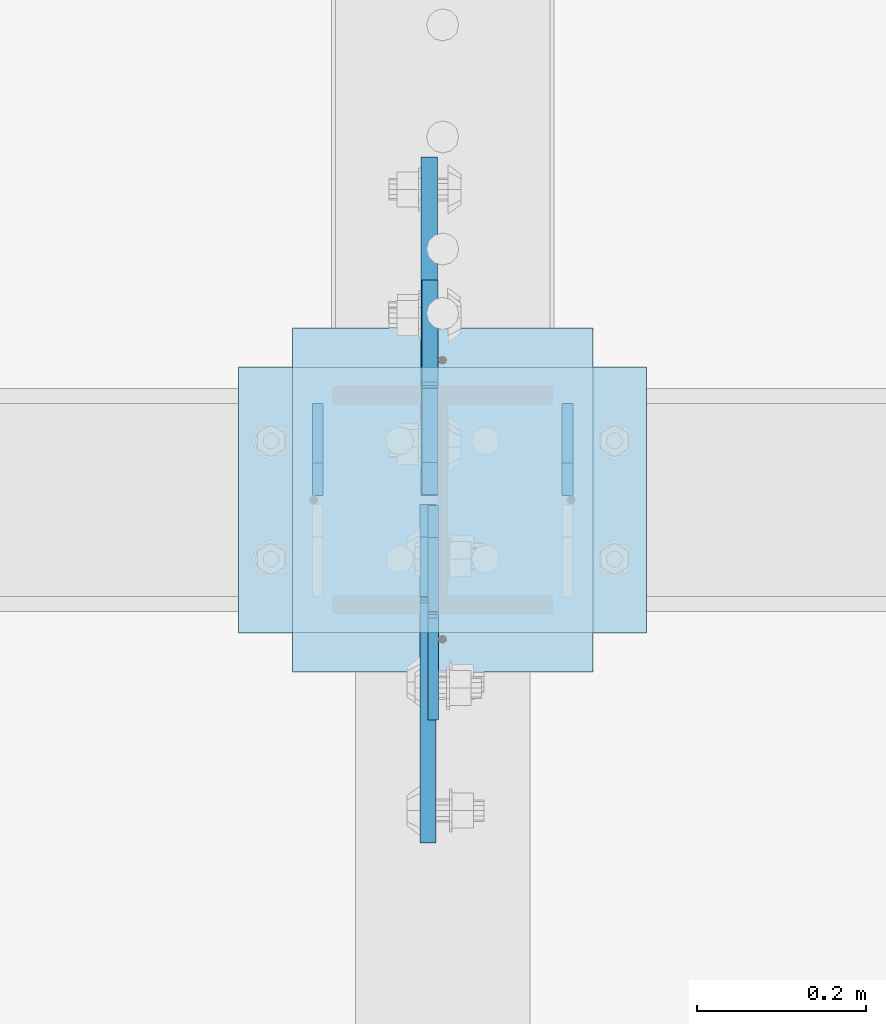
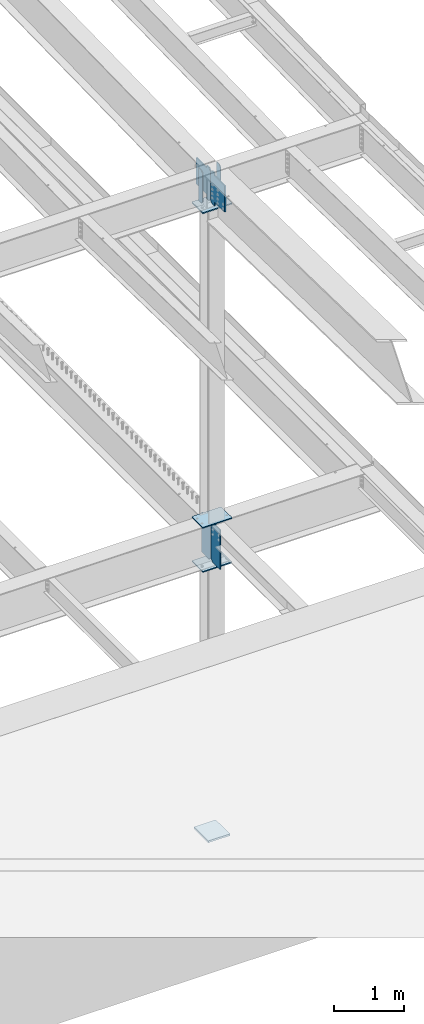
# One storey, part 1583 of 1763: 10 plates, 4 elements without a shape of their own.
"""IFC2X3 building model written with IfcOpenShell, lengths in millimetres."""

from ifc_helpers import new_model, si_unit, frame, origin_with_axes, place, context, subcontext, project, spatial, faceted_brep, material, type_object, element, aggregate, save


model = new_model("IFC2X3")

# Units and contexts
model_context = context("Model", 3, precision=1e-05, world=origin_with_axes())
body_context = subcontext(model_context, "Body", "Model", "MODEL_VIEW")
ifc_project = project(units=[si_unit("LENGTHUNIT", "METRE", prefix="MILLI"), si_unit("AREAUNIT", "SQUARE_METRE"), si_unit("VOLUMEUNIT", "CUBIC_METRE"), si_unit("MASSUNIT", "GRAM", prefix="KILO"), si_unit("TIMEUNIT", "SECOND"), si_unit("PLANEANGLEUNIT", "RADIAN"), si_unit("SOLIDANGLEUNIT", "STERADIAN"), si_unit("THERMODYNAMICTEMPERATUREUNIT", "DEGREE_CELSIUS"), si_unit("LUMINOUSINTENSITYUNIT", "LUMEN")], contexts=[model_context])

# Site, building, storey
site_placement = place(None, origin_with_axes())
site = spatial("IfcSite", under=ifc_project, at=site_placement, CompositionType="ELEMENT")
building_placement = place(site_placement, origin_with_axes())
building = spatial("IfcBuilding", under=site, at=building_placement, Name="Undefined", CompositionType="ELEMENT")
storey_placement = place(building_placement, origin_with_axes())
storey = spatial("IfcBuildingStorey", under=building, at=storey_placement, Name="Undefined", CompositionType="ELEMENT", Elevation=0.0)

# Assembly, plates
assembly_1_placement = place(storey_placement, origin_with_axes())
assembly_1 = element("IfcElementAssembly", 1, at=assembly_1_placement, inside=storey, Name="BEAM", AssemblyPlace="NOTDEFINED", PredefinedType="RIGID_FRAME")
ifc_material_1 = material(Name="STEEL/A572-50")
plate_type_1 = type_object("IfcPlateType", PredefinedType="NOTDEFINED")
plate_1_placement = place(assembly_1_placement, frame((-24175.4747736984, 30137.1000001452, 11272.8374999952), z_axis=(0.0, 0.0, -1.0), x_axis=(0.0, -1.0, 0.0)))
plate_1 = element("IfcPlate", 2, at=plate_1_placement, type_object=plate_type_1, material=ifc_material_1, Name="PLATE", context=body_context, shape_type="Brep", body=[
    faceted_brep([(0.0, -6.34999999999491, 1.45519152283669e-11), (0.0, -6.34999999999854, 571.5), (0.0, 6.34999999999854, 571.5), (0.0, 6.34999999999491, -2.91038304567337e-11), (70.6437530517578, -6.34999999999854, 571.5), (70.6437530517578, 6.34999999999854, 571.5), (108.743751525879, -6.34999999999854, 533.400001525879), (108.743751525879, 6.34999999999854, 533.400001525879), (108.743751525879, -6.34999999999854, 38.0999984741211), (108.743751525879, 6.34999999999854, 38.0999984741211), (70.6437530517578, -6.34999999999854, 0.0), (70.6437530517578, 6.34999999999854, 0.0)], [[[0, 1, 2, 3]], [[1, 4, 5, 2]], [[4, 6, 7, 5]], [[6, 8, 9, 7]], [[8, 10, 11, 9]], [[10, 0, 3, 11]], [[5, 7, 9, 11, 3, 2]], [[10, 8, 6, 4, 1, 0]]]),
])
plate_2_placement = place(assembly_1_placement, frame((-23880.1997736984, 30137.1000001452, 11272.8374999952), z_axis=(0.0, 0.0, -1.0), x_axis=(0.0, -1.0, 0.0)))
plate_2 = element("IfcPlate", 3, at=plate_2_placement, type_object=plate_type_1, material=ifc_material_1, Name="PLATE", context=body_context, shape_type="Brep", body=[
    faceted_brep([(0.0, -6.34999999999491, 1.45519152283669e-11), (0.0, -6.34999999999854, 571.5), (0.0, 6.34999999999854, 571.5), (0.0, 6.34999999999491, -2.91038304567337e-11), (70.6437530517578, -6.34999999999854, 571.5), (70.6437530517578, 6.34999999999854, 571.5), (108.743751525879, -6.34999999999854, 533.400001525879), (108.743751525879, 6.34999999999854, 533.400001525879), (108.743751525879, -6.34999999999854, 38.0999984741211), (108.743751525879, 6.34999999999854, 38.0999984741211), (70.6437530517578, -6.34999999999854, 0.0), (70.6437530517578, 6.34999999999854, 0.0)], [[[0, 1, 2, 3]], [[1, 4, 5, 2]], [[4, 6, 7, 5]], [[6, 8, 9, 7]], [[8, 10, 11, 9]], [[10, 0, 3, 11]], [[5, 7, 9, 11, 3, 2]], [[10, 8, 6, 4, 1, 0]]]),
])

# Assembly, plate
assembly_2_placement = place(storey_placement, origin_with_axes())
assembly_2 = element("IfcElementAssembly", 4, at=assembly_2_placement, inside=storey, Name="COLUMN", AssemblyPlace="NOTDEFINED", PredefinedType="RIGID_FRAME")
plate_type_2 = type_object("IfcPlateType", PredefinedType="NOTDEFINED")
plate_3_placement = place(assembly_2_placement, frame((-24269.1372736984, 30179.9625, 5203.825), z_axis=(1.0, 0.0, 0.0), x_axis=(0.0, -1.0, 0.0)))
plate_3 = element("IfcPlate", 5, at=plate_3_placement, type_object=plate_type_2, material=ifc_material_1, Name="PLATE", context=body_context, shape_type="Brep", body=[
    faceted_brep([(0.0, -9.52500000000146, 0.0), (0.0, -9.52499999999964, 482.600006103516), (0.0, 9.52499999999964, 482.600006103516), (0.0, 9.52500000000146, 0.0), (314.325012207031, -9.52499999999964, 482.600006103516), (314.325012207031, 9.52499999999964, 482.600006103516), (314.325012207031, -9.52499999999964, 0.0), (314.325012207031, 9.52499999999964, 0.0)], [[[0, 1, 2, 3]], [[1, 4, 5, 2]], [[4, 6, 7, 5]], [[6, 0, 3, 7]], [[5, 7, 3, 2]], [[6, 4, 1, 0]]]),
])

assembly_3_placement = place(storey_placement, origin_with_axes())
assembly_3 = element("IfcElementAssembly", 6, at=assembly_3_placement, inside=storey, Name="COLUMN", AssemblyPlace="NOTDEFINED", PredefinedType="RIGID_FRAME")
plate_4_placement = place(assembly_3_placement, frame((-23786.5372736984, 30179.9625, 4435.475), z_axis=(-1.0, 0.0, 0.0), x_axis=(0.0, -1.0, 0.0)))
plate_4 = element("IfcPlate", 7, at=plate_4_placement, type_object=plate_type_2, material=ifc_material_1, Name="PLATE", context=body_context, shape_type="Brep", body=[
    faceted_brep([(0.0, -9.52500000000146, 0.0), (0.0, -9.52499999999964, 482.600006103516), (0.0, 9.52499999999964, 482.600006103516), (0.0, 9.52500000000146, 0.0), (314.325012207031, -9.52499999999964, 482.600006103516), (314.325012207031, 9.52499999999964, 482.600006103516), (314.325012207031, -9.52499999999964, 0.0), (314.325012207031, 9.52499999999964, 0.0)], [[[0, 1, 2, 3]], [[1, 4, 5, 2]], [[4, 6, 7, 5]], [[6, 0, 3, 7]], [[5, 7, 3, 2]], [[6, 4, 1, 0]]]),
])

# Plate
plate_5_placement = place(assembly_2_placement, frame((-23786.5372736984, 30179.9625, 10674.3499999952), z_axis=(-1.0, 0.0, 0.0), x_axis=(0.0, -1.0, 0.0)))
plate_5 = element("IfcPlate", 8, at=plate_5_placement, type_object=plate_type_2, material=ifc_material_1, Name="PLATE", context=body_context, shape_type="Brep", body=[
    faceted_brep([(0.0, -9.52500000000146, 0.0), (0.0, -9.52499999999964, 482.600006103516), (0.0, 9.52499999999964, 482.600006103516), (0.0, 9.52500000000146, 0.0), (314.325012207031, -9.52499999999964, 482.600006103516), (314.325012207031, 9.52499999999964, 482.600006103516), (314.325012207031, -9.52499999999964, 0.0), (314.325012207031, 9.52499999999964, 0.0)], [[[0, 1, 2, 3]], [[1, 4, 5, 2]], [[4, 6, 7, 5]], [[6, 0, 3, 7]], [[5, 7, 3, 2]], [[6, 4, 1, 0]]]),
])

aggregate(assembly_2, [plate_3, plate_5])

# Assembly, plates
assembly_4_placement = place(storey_placement, origin_with_axes())
assembly_4 = element("IfcElementAssembly", 9, at=assembly_4_placement, inside=storey, Name="BEAM", AssemblyPlace="NOTDEFINED", PredefinedType="RIGID_FRAME")
plate_type_3 = type_object("IfcPlateType", PredefinedType="NOTDEFINED")
plate_6_placement = place(assembly_4_placement, frame((-24038.9497737937, 30016.45, 4462.4625), z_axis=(0.0, 0.0, 1.0), x_axis=(0.0, -1.0, 0.0)))
plate_6 = element("IfcPlate", 10, at=plate_6_placement, type_object=plate_type_3, material=ifc_material_1, Name="PLATE", context=body_context, shape_type="Brep", body=[
    faceted_brep([(125.41249998708, -6.34999999999854, 715.962524414062), (125.41250129469, -6.34999999999854, 706.437506166973), (125.41250129469, 6.34999999999854, 706.437506166973), (125.41249998708, 6.34999999999854, 715.962524414062), (126.379231616829, -6.34999999999854, 701.577427427796), (126.379231616829, 6.34999999999854, 701.577427427796), (129.132245361488, -6.34999999999854, 697.457251680518), (129.132245361488, 6.34999999999854, 697.457251680518), (133.25242125821, -6.34999999999854, 694.704238159517), (133.25242125821, 6.34999999999854, 694.704238159517), (138.112500049865, -6.34999999999854, 693.737508101197), (138.112500049865, 6.34999999999854, 693.737508101197), (253.99999693465, -6.34999999999854, 693.737498482747), (254.0, 6.34999999999854, 693.737498482747), (0.0, -6.34999999999854, 677.862525939941), (38.0999984741211, -6.34999999999854, 715.962524414062), (38.0999984741211, 6.34999999999854, 715.962524414062), (0.0, 6.34999999999854, 677.862525939941), (0.0, -6.34999999999854, 38.0999984741211), (0.0, 6.34999999999854, 38.0999984741211), (38.0999984741211, -6.34999999999854, 0.0), (38.0999984741211, 6.34999999999854, 0.0), (254.0, -6.34999999999854, 0.0), (254.0, 6.34999999999854, 0.0)], [[[0, 1, 2, 3]], [[4, 5, 2, 1]], [[6, 7, 5, 4]], [[8, 9, 7, 6]], [[10, 11, 9, 8]], [[12, 13, 11, 10]], [[14, 15, 16, 17]], [[18, 14, 17, 19]], [[20, 18, 19, 21]], [[22, 20, 21, 23]], [[8, 6, 4, 1, 0, 15, 14, 18, 20, 22, 12, 10]], [[16, 15, 0, 3]], [[23, 21, 19, 17, 16, 3, 2, 5, 7, 9, 11, 13]], [[22, 23, 13, 12]]]),
])
plate_type_4 = type_object("IfcPlateType", PredefinedType="NOTDEFINED")
plate_7_placement = place(assembly_4_placement, frame((-24042.9185240798, 30029.15, 4462.4625), z_axis=(0.0, 0.0, 1.0), x_axis=(0.0, 1.0, 0.0)))
plate_7 = element("IfcPlate", 11, at=plate_7_placement, type_object=plate_type_4, material=ifc_material_1, Name="PLATE", context=body_context, shape_type="Brep", body=[
    faceted_brep([(125.412994384773, -9.52500000000146, 715.962524414062), (125.412994384773, -9.52500000000146, 696.912487602234), (125.412994384773, 9.52500000000146, 696.912487602234), (125.412994384773, 9.52500000000146, 715.962524414062), (126.37972430736, -9.52500000000146, 692.052408084189), (126.37972430736, 9.52500000000146, 692.052408084189), (129.132738207838, -9.52500000000146, 687.932231616035), (129.132738207838, 9.52500000000146, 687.932231616035), (133.252914675992, -9.52500000000146, 685.179217715557), (133.252914675992, 9.52500000000146, 685.179217715557), (138.112994194038, -9.52500000000146, 684.212487792969), (138.112994194038, 9.52500000000146, 684.212487792969), (254.000000000007, -9.52500000000146, 684.212487792969), (254.0, 9.52500000000146, 684.212487792969), (0.0, -9.52500000000146, 677.862525939941), (38.0999984741211, -9.52500000000146, 715.962524414062), (38.0999984741211, 9.52500000000146, 715.962524414062), (0.0, 9.52500000000146, 677.862525939941), (0.0, -9.52500000000146, 38.0999984741211), (0.0, 9.52500000000146, 38.0999984741211), (38.0999984741211, -9.52500000000146, 0.0), (38.0999984741211, 9.52500000000146, 0.0), (254.0, -9.52500000000146, 0.0), (254.0, 9.52500000000146, 0.0)], [[[0, 1, 2, 3]], [[4, 5, 2, 1]], [[6, 7, 5, 4]], [[8, 9, 7, 6]], [[10, 11, 9, 8]], [[12, 13, 11, 10]], [[14, 15, 16, 17]], [[18, 14, 17, 19]], [[20, 18, 19, 21]], [[22, 20, 21, 23]], [[8, 6, 4, 1, 0, 15, 14, 18, 20, 22, 12, 10]], [[16, 15, 0, 3]], [[23, 21, 19, 17, 16, 3, 2, 5, 7, 9, 11, 13]], [[22, 23, 13, 12]]]),
])
aggregate(assembly_4, [plate_6, plate_7])

# Plate
plate_type_5 = type_object("IfcPlateType", PredefinedType="NOTDEFINED")
plate_8_placement = place(assembly_1_placement, frame((-24045.2997740798, 30017.2437501452, 10701.3374999952), z_axis=(0.0, 0.0, 1.0), x_axis=(0.0, -1.0, 0.0)))
plate_8 = element("IfcPlate", 12, at=plate_8_placement, type_object=plate_type_5, material=ifc_material_1, Name="PLATE", context=body_context, shape_type="Brep", body=[
    faceted_brep([(108.743749999998, -9.52500000000146, 571.5), (108.743749999998, -9.52500000000146, 539.476292991638), (108.743749999998, 9.52500000000146, 539.476292991638), (108.743749999998, 9.52500000000146, 571.5), (109.710479922585, -9.52500000000146, 534.616213473591), (109.710479922585, 9.52500000000146, 534.616213473591), (112.463493823063, -9.52500000000146, 530.496037005438), (112.463493823063, 9.52500000000146, 530.496037005438), (116.583670291217, -9.52500000000146, 527.74302310496), (116.583670291217, 9.52500000000146, 527.74302310496), (121.443749809263, -9.52500000000146, 526.776293182373), (121.443749809263, 9.52500000000146, 526.776293182373), (400.049993896482, -9.52500000000146, 526.776293182373), (400.049987792969, 9.52500000000146, 526.776293182373), (0.0, -9.52500000000146, 533.400001525879), (38.0999984741211, -9.52500000000146, 571.5), (38.0999984741211, 9.52500000000146, 571.5), (0.0, 9.52500000000146, 533.400001525879), (0.0, -9.52500000000146, 38.0999984741211), (0.0, 9.52500000000146, 38.0999984741211), (38.0999984741211, -9.52500000000146, 0.0), (38.0999984741211, 9.52500000000146, 0.0), (108.743749854828, 9.52500000000146, 0.0), (108.743749854828, -9.52500000000146, 0.0), (108.743749854828, 9.52500000000146, 56.8731378434532), (108.743749854828, -9.52500000000146, 56.8731378434532), (109.710477709006, 9.52500000000146, 61.7332123679098), (109.710477709006, -9.52500000000146, 61.7332123679098), (112.463486034045, 9.52500000000146, 65.8533861857959), (112.463486034045, -9.52500000000146, 65.8533861857959), (116.583655165286, 9.52500000000146, 68.6064015248849), (116.583655165286, -9.52500000000146, 68.6064015248849), (121.443728044011, 9.52500000000146, 69.5731376527001), (121.443728044011, -9.52500000000146, 69.5731376527001), (400.049993751312, -9.52500000000146, 69.5736119432986), (400.049987792969, 9.52500000000146, 69.5736119432986)], [[[0, 1, 2, 3]], [[4, 5, 2, 1]], [[6, 7, 5, 4]], [[8, 9, 7, 6]], [[10, 11, 9, 8]], [[12, 13, 11, 10]], [[14, 15, 16, 17]], [[18, 14, 17, 19]], [[20, 18, 19, 21]], [[20, 21, 22, 23]], [[23, 22, 24, 25]], [[25, 24, 26, 27]], [[27, 26, 28, 29]], [[29, 28, 30, 31]], [[31, 30, 32, 33]], [[34, 33, 32, 35]], [[8, 6, 4, 1, 0, 15, 14, 18, 20, 23, 25, 27, 29, 31, 33, 34, 12, 10]], [[16, 15, 0, 3]], [[35, 32, 30, 28, 26, 24, 22, 21, 19, 17, 16, 3, 2, 5, 7, 9, 11, 13]], [[34, 35, 13, 12]]]),
])

plate_9_placement = place(assembly_1_placement, frame((-24043.7122740798, 30028.3562501452, 10701.3374999952), z_axis=(0.0, 0.0, 1.0), x_axis=(0.0, 1.0, 0.0)))
plate_9 = element("IfcPlate", 13, at=plate_9_placement, type_object=plate_type_5, material=ifc_material_1, Name="PLATE", context=body_context, shape_type="Brep", body=[
    faceted_brep([(108.743749999998, -9.52500000000146, 571.5), (108.743749999998, -9.52500000000146, 539.476292991638), (108.743749999998, 9.52500000000146, 539.476292991638), (108.743749999998, 9.52500000000146, 571.5), (109.710479922585, -9.52500000000146, 534.616213473591), (109.710479922585, 9.52500000000146, 534.616213473591), (112.463493823063, -9.52500000000146, 530.496037005438), (112.463493823063, 9.52500000000146, 530.496037005438), (116.583670291217, -9.52500000000146, 527.74302310496), (116.583670291217, 9.52500000000146, 527.74302310496), (121.443749809263, -9.52500000000146, 526.776293182373), (121.443749809263, 9.52500000000146, 526.776293182373), (400.049993896482, -9.52500000000146, 526.776293182373), (400.049987792969, 9.52500000000146, 526.776293182373), (0.0, -9.52500000000146, 533.400001525879), (38.0999984741211, -9.52500000000146, 571.5), (38.0999984741211, 9.52500000000146, 571.5), (0.0, 9.52500000000146, 533.400001525879), (0.0, -9.52500000000146, 38.0999984741211), (0.0, 9.52500000000146, 38.0999984741211), (38.0999984741211, -9.52500000000146, 0.0), (38.0999984741211, 9.52500000000146, 0.0), (108.743749854828, 9.52500000000146, 0.0), (108.743749854828, -9.52500000000146, 0.0), (108.743749854828, 9.52500000000146, 56.8731378434532), (108.743749854828, -9.52500000000146, 56.8731378434532), (109.710477709006, 9.52500000000146, 61.7332123679098), (109.710477709006, -9.52500000000146, 61.7332123679098), (112.463486034045, 9.52500000000146, 65.8533861857959), (112.463486034045, -9.52500000000146, 65.8533861857959), (116.583655165286, 9.52500000000146, 68.6064015248849), (116.583655165286, -9.52500000000146, 68.6064015248849), (121.443728044011, 9.52500000000146, 69.5731376527001), (121.443728044011, -9.52500000000146, 69.5731376527001), (400.049993751312, -9.52500000000146, 69.5736119432986), (400.049987792969, 9.52500000000146, 69.5736119432986)], [[[0, 1, 2, 3]], [[4, 5, 2, 1]], [[6, 7, 5, 4]], [[8, 9, 7, 6]], [[10, 11, 9, 8]], [[12, 13, 11, 10]], [[14, 15, 16, 17]], [[18, 14, 17, 19]], [[20, 18, 19, 21]], [[20, 21, 22, 23]], [[23, 22, 24, 25]], [[25, 24, 26, 27]], [[27, 26, 28, 29]], [[29, 28, 30, 31]], [[31, 30, 32, 33]], [[34, 33, 32, 35]], [[8, 6, 4, 1, 0, 15, 14, 18, 20, 23, 25, 27, 29, 31, 33, 34, 12, 10]], [[16, 15, 0, 3]], [[35, 32, 30, 28, 26, 24, 22, 21, 19, 17, 16, 3, 2, 5, 7, 9, 11, 13]], [[34, 35, 13, 12]]]),
])

aggregate(assembly_1, [plate_1, plate_2, plate_8, plate_9])

ifc_material_2 = material(Name="STEEL/A36")
plate_type_6 = type_object("IfcPlateType", PredefinedType="NOTDEFINED")
plate_10_placement = place(assembly_3_placement, frame((-24205.6372736984, 30226.0, -250.825000000001), z_axis=(1.0, 0.0, 0.0), x_axis=(0.0, -1.0, 0.0)))
plate_10 = element("IfcPlate", 14, at=plate_10_placement, type_object=plate_type_6, material=ifc_material_2, Name="PLATE", context=body_context, shape_type="Brep", body=[
    faceted_brep([(0.0, -15.875, 0.0), (0.0, -15.875, 355.600006103516), (0.0, 15.875, 355.600006103516), (0.0, 15.875, 0.0), (406.399993896484, -15.875, 355.600006103516), (406.399993896484, 15.875, 355.600006103516), (406.399993896484, -15.875, 0.0), (406.399993896484, 15.875, 0.0)], [[[0, 1, 2, 3]], [[1, 4, 5, 2]], [[4, 6, 7, 5]], [[6, 0, 3, 7]], [[5, 7, 3, 2]], [[6, 4, 1, 0]]]),
])

aggregate(assembly_3, [plate_4, plate_10])

save(model, "model.ifc")
